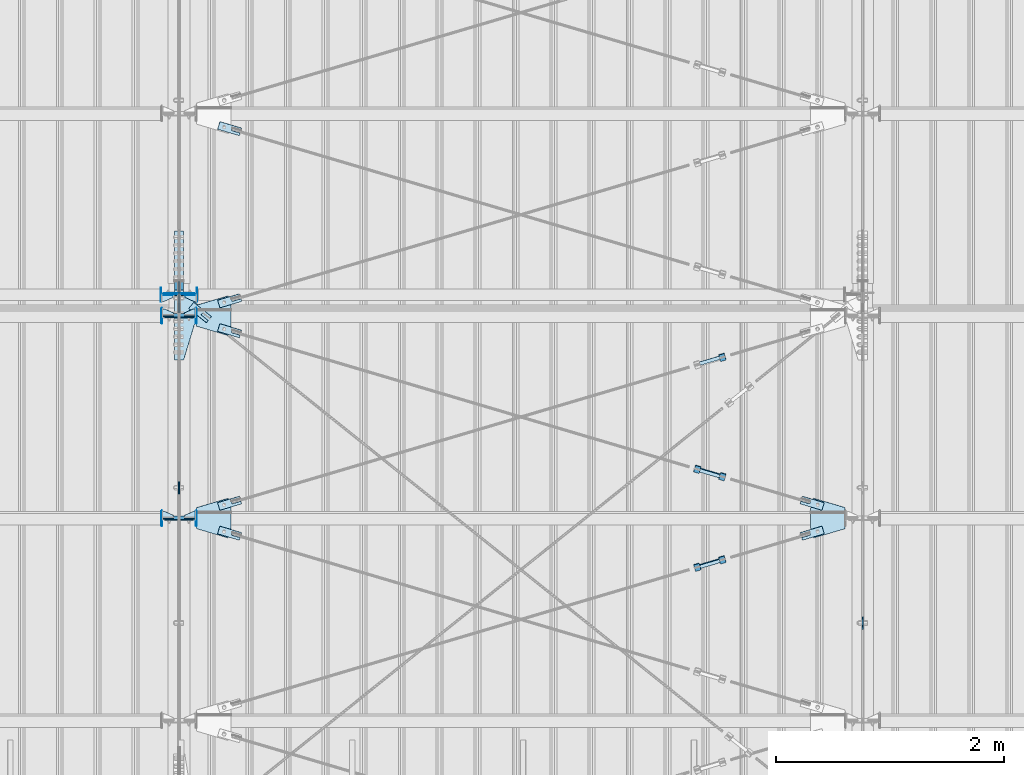
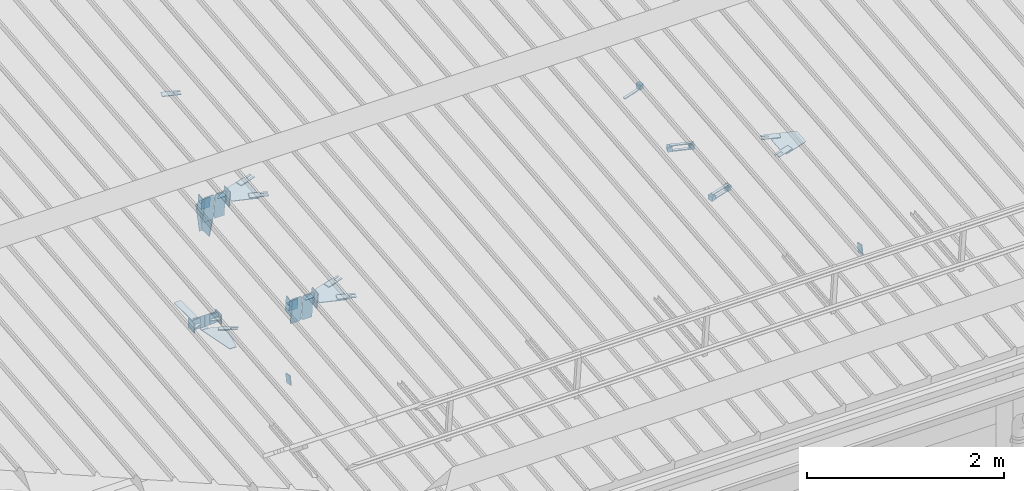
# One storey, part 148 of 709: 51 plates, 7 openings, 21 elements without a shape of their own.
"""IFC4 building model written with IfcOpenShell, lengths in millimetres."""

from ifc_helpers import new_model, si_unit, direction, frame, origin_with_axes, place, context, subcontext, project, spatial, line, indexed_curve, outline, extrude, material, element, aggregate, save


model = new_model("IFC4")

# Units and contexts
model_context = context("Model", 3, precision=0.2, world=origin_with_axes(), true_north=direction((0.0, 1.0)))
body_context = subcontext(model_context, "Body", "Model", "MODEL_VIEW")
ifc_project = project(units=[si_unit("LENGTHUNIT", "METRE", prefix="MILLI"), si_unit("AREAUNIT", "SQUARE_METRE"), si_unit("VOLUMEUNIT", "CUBIC_METRE"), si_unit("MASSUNIT", "GRAM", prefix="KILO"), si_unit("TIMEUNIT", "SECOND"), si_unit("PLANEANGLEUNIT", "RADIAN"), si_unit("SOLIDANGLEUNIT", "STERADIAN"), si_unit("THERMODYNAMICTEMPERATUREUNIT", "DEGREE_CELSIUS"), si_unit("LUMINOUSINTENSITYUNIT", "LUMEN")], contexts=[model_context])

# Site, building, storey
site_placement = place(None, origin_with_axes())
site = spatial("IfcSite", under=ifc_project, at=site_placement, CompositionType="ELEMENT")
building_placement = place(site_placement, origin_with_axes())
building = spatial("IfcBuilding", under=site, at=building_placement, Name="Undefined", CompositionType="ELEMENT")
storey_placement = place(building_placement, origin_with_axes())
storey = spatial("IfcBuildingStorey", under=building, at=storey_placement, Name="Undefined", CompositionType="ELEMENT", Elevation=0.0)

# Assembly, plates
assembly_1_placement = place(storey_placement, frame((40000.0, 346.0, 7089.70002), z_axis=(1.0, 0.0, 0.0), x_axis=(0.0, 0.9950371902, 0.099503719)))
assembly_1 = element("IfcElementAssembly", 1, at=assembly_1_placement, inside=storey)
ifc_material_1 = material(Name="C355-6", Category="STEEL")
plate_1_placement = place(assembly_1_placement, frame((5169.0059, 163.0, 127.0), z_axis=(-1.0, 0.0, 0.0), x_axis=(0.0, 0.0, -1.0)))
plate_1 = element("IfcPlate", 2, at=plate_1_placement, material=ifc_material_1, ObjectType="585", context=body_context, shape_type="SolidModel", body=[
    extrude(outline(indexed_curve([(0.0, 0.0), (108.0, 0.0), (123.0, 15.0), (123.0, 311.0), (108.0, 326.0), (0.0, 326.0)], segments=[line(1, 2, 3, 4, 5, 6, 1)])), frame((0.0, 0.0, 4.0), z_axis=(0.0, 0.0, 1.0), x_axis=(1.0, 0.0, 0.0)), (0.0, 0.0, -1.0), 8.0),
])
plate_2_placement = place(assembly_1_placement, frame((5169.0059, 163.0, -127.0), z_axis=(1.0, 0.0, 0.0), x_axis=(0.0, 0.0, 1.0)))
plate_2 = element("IfcPlate", 3, at=plate_2_placement, material=ifc_material_1, ObjectType="585", context=body_context, shape_type="SolidModel", body=[
    extrude(outline(indexed_curve([(0.0, 0.0), (108.0, 0.0), (123.0, 15.0), (123.0, 311.0), (108.0, 326.0), (0.0, 326.0)], segments=[line(1, 2, 3, 4, 5, 6, 1)])), frame((0.0, 0.0, 4.0), z_axis=(0.0, 0.0, 1.0), x_axis=(1.0, 0.0, 0.0)), (0.0, 0.0, -1.0), 8.0),
])
plate_3_placement = place(assembly_1_placement, frame((3383.44474, 163.0, 127.0), z_axis=(-1.0, 0.0, 0.0), x_axis=(0.0, 0.0, -1.0)))
plate_3 = element("IfcPlate", 4, at=plate_3_placement, material=ifc_material_1, ObjectType="585", context=body_context, shape_type="SolidModel", body=[
    extrude(outline(indexed_curve([(0.0, 0.0), (108.0, 0.0), (123.0, 15.0), (123.0, 311.0), (108.0, 326.0), (0.0, 326.0)], segments=[line(1, 2, 3, 4, 5, 6, 1)])), frame((0.0, 0.0, 4.0), z_axis=(0.0, 0.0, 1.0), x_axis=(1.0, 0.0, 0.0)), (0.0, 0.0, -1.0), 8.0),
])
plate_4_placement = place(assembly_1_placement, frame((3383.44474, 163.0, -127.0), z_axis=(1.0, 0.0, 0.0), x_axis=(0.0, 0.0, 1.0)))
plate_4 = element("IfcPlate", 5, at=plate_4_placement, material=ifc_material_1, ObjectType="585", context=body_context, shape_type="SolidModel", body=[
    extrude(outline(indexed_curve([(0.0, 0.0), (108.0, 0.0), (123.0, 15.0), (123.0, 311.0), (108.0, 326.0), (0.0, 326.0)], segments=[line(1, 2, 3, 4, 5, 6, 1)])), frame((0.0, 0.0, 4.0), z_axis=(0.0, 0.0, 1.0), x_axis=(1.0, 0.0, 0.0)), (0.0, 0.0, -1.0), 8.0),
])
plate_5_placement = place(assembly_1_placement, frame((5220.02987, -437.93487, 0.0), z_axis=(0.0, 0.0, -1.0), x_axis=(-0.1614213634, 0.9868855777, 0.0)))
plate_5 = element("IfcPlate", 6, at=plate_5_placement, material=ifc_material_1, ObjectType="442", context=body_context, shape_type="SolidModel", body=[
    extrude(outline(indexed_curve([(0.0, 0.0), (270.19115, 0.0), (225.20717, 275.01958), (-33.64648, 125.57036)], segments=[line(1, 2, 3, 4, 1)])), frame((0.0, 0.0, 6.0), z_axis=(0.0, 0.0, 1.0), x_axis=(1.0, 0.0, 0.0)), (0.0, 0.0, -1.0), 12.0),
])
plate_6_placement = place(assembly_1_placement, frame((5458.83099, -172.70172, -40.0), z_axis=(-0.9353786626, 0.3536477874, 0.0), x_axis=(-0.3536477874, -0.9353786626, 0.0)))
plate_6 = element("IfcPlate", 7, at=plate_6_placement, material=ifc_material_1, ObjectType="443", context=body_context, shape_type="SolidModel", body=[
    extrude(outline(indexed_curve([(0.0, 0.0), (298.89845, 0.0), (298.89845, 80.0), (0.0, 80.0)], segments=[line(1, 2, 3, 4, 1)])), frame((0.0, 0.0, 4.0), z_axis=(0.0, 0.0, 1.0), x_axis=(1.0, 0.0, 0.0)), (0.0, 0.0, -1.0), 8.0),
])
aggregate(assembly_1, [plate_1, plate_2, plate_3, plate_4, plate_5, plate_6])

# Assembly, plate
assembly_2_placement = place(storey_placement, frame((40000.0, 5665.09652, 5984.78262), z_axis=(-0.625451877, -0.7802627439, 1e-10), x_axis=(0.7742288439, -0.6206151549, 0.124123031)))
assembly_2 = element("IfcElementAssembly", 8, at=assembly_2_placement, inside=storey)
plate_7_placement = place(assembly_2_placement, frame((338.57474, -5.35577, -34.5878), z_axis=(1e-10, 0.9882227648, -0.1530221135), x_axis=(-1.0, 0.0, 0.0)))
plate_7 = element("IfcPlate", 9, at=plate_7_placement, material=ifc_material_1, ObjectType="488", context=body_context, shape_type="SolidModel", body=[
    extrude(outline(indexed_curve([(0.0, 0.0), (200.0, 0.0), (200.0, 70.0), (0.0, 70.0), (0.0, 46.0), (80.0, 46.0), (80.0, 24.0), (0.0, 24.0)], segments=[line(1, 2, 3, 4, 5, 6, 7, 8, 1)])), frame((0.0, 0.0, 4.0), z_axis=(0.0, 0.0, 1.0), x_axis=(1.0, 0.0, 0.0)), (0.0, 0.0, -1.0), 8.0),
])
aggregate(assembly_2, [plate_7])

# Assembly, plates
assembly_3_placement = place(storey_placement, frame((40000.0, 5668.61344, 5980.00002), z_axis=(1.0, 0.0, 0.0), x_axis=(0.0, 1.0, 0.0)))
assembly_3 = element("IfcElementAssembly", 10, at=assembly_3_placement, inside=storey)
plate_8_placement = place(assembly_3_placement, frame((12.38656, 164.3, 134.0), z_axis=(-1.0, 0.0, 0.0), x_axis=(0.0, 0.0, -1.0)))
plate_8 = element("IfcPlate", 11, at=plate_8_placement, material=ifc_material_1, ObjectType="558", context=body_context, shape_type="SolidModel", body=[
    extrude(outline(indexed_curve([(0.0, 0.0), (130.0, 0.0), (130.0, 140.0), (0.0, 140.0)], segments=[line(1, 2, 3, 4, 1)])), frame((0.0, 0.0, 4.0), z_axis=(0.0, 0.0, 1.0), x_axis=(1.0, 0.0, 0.0)), (0.0, 0.0, -1.0), 8.0),
])
plate_9_placement = place(assembly_3_placement, frame((12.38656, 164.3, -134.0), z_axis=(1.0, 0.0, 0.0), x_axis=(0.0, 0.0, 1.0)))
plate_9 = element("IfcPlate", 12, at=plate_9_placement, material=ifc_material_1, ObjectType="558", context=body_context, shape_type="SolidModel", body=[
    extrude(outline(indexed_curve([(0.0, 0.0), (130.0, 0.0), (130.0, 140.0), (0.0, 140.0)], segments=[line(1, 2, 3, 4, 1)])), frame((0.0, 0.0, 4.0), z_axis=(0.0, 0.0, 1.0), x_axis=(1.0, 0.0, 0.0)), (0.0, 0.0, -1.0), 8.0),
])
plate_10_placement = place(assembly_3_placement, frame((-0.78446, -3.92232, 40.0), z_axis=(0.1961161349, 0.9805806757, 0.0), x_axis=(0.0, 0.0, -1.0)))
plate_10 = element("IfcPlate", 13, at=plate_10_placement, material=ifc_material_1, ObjectType="487", context=body_context, shape_type="SolidModel", body=[
    extrude(outline(indexed_curve([(0.0, 0.0), (80.0, 0.0), (80.0, 579.50696), (0.0, 579.50696), (-116.23068, 190.22219), (-173.1922, 120.5416), (-95.76932, 57.25102)], segments=[line(1, 2, 3, 4, 5, 6, 7, 1)])), frame((0.0, 0.0, 4.0), z_axis=(0.0, 0.0, 1.0), x_axis=(1.0, 0.0, 0.0)), (0.0, 0.0, -1.0), 8.0),
])
plate_11_placement = place(assembly_3_placement, frame((564.38656, -4.0, -40.0), z_axis=(0.0, 1.0, 0.0), x_axis=(-1.0, 0.0, 0.0)))
plate_11 = element("IfcPlate", 14, at=plate_11_placement, material=ifc_material_1, ObjectType="446", context=body_context, shape_type="SolidModel", body=[
    extrude(outline(indexed_curve([(0.0, 0.0), (564.38656, 0.0), (564.38656, 80.0), (0.0, 80.0)], segments=[line(1, 2, 3, 4, 1)])), frame((0.0, 0.0, 4.0), z_axis=(0.0, 0.0, 1.0), x_axis=(1.0, 0.0, 0.0)), (0.0, 0.0, -1.0), 8.0),
])
aggregate(assembly_3, [plate_8, plate_9, plate_10, plate_11])

# Assembly, plate
assembly_4_placement = place(storey_placement, frame((40000.0, 3946.08299, 6446.88258), z_axis=(-1.0, 0.0, 0.0), x_axis=(0.0, 0.9805806757, -0.1961161349)))
assembly_4 = element("IfcElementAssembly", 15, at=assembly_4_placement, inside=storey)
plate_12_placement = place(assembly_4_placement, origin_with_axes())
plate_12 = element("IfcPlate", 16, at=plate_12_placement, material=ifc_material_1, ObjectType="491", context=body_context, shape_type="SolidModel", body=[
    extrude(outline(indexed_curve([(0.0, 0.0), (90.0, 0.0), (90.0, 110.0), (0.0, 110.0)], segments=[line(1, 2, 3, 4, 1)])), frame((0.0, 0.0, 6.0), z_axis=(0.0, 0.0, 1.0), x_axis=(1.0, 0.0, 0.0)), (0.0, 0.0, -1.0), 12.0),
])
aggregate(assembly_4, [plate_12])

assembly_5_placement = place(storey_placement, frame((46000.0, 2758.46612, 6684.40595), z_axis=(-1.0, 0.0, 0.0), x_axis=(0.0, 0.9805806757, -0.1961161349)))
assembly_5 = element("IfcElementAssembly", 17, at=assembly_5_placement, inside=storey)
plate_13_placement = place(assembly_5_placement, origin_with_axes())
plate_13 = element("IfcPlate", 18, at=plate_13_placement, material=ifc_material_1, ObjectType="491", context=body_context, shape_type="SolidModel", body=[
    extrude(outline(indexed_curve([(0.0, 0.0), (90.0, 0.0), (90.0, 110.0), (0.0, 110.0)], segments=[line(1, 2, 3, 4, 1)])), frame((0.0, 0.0, 6.0), z_axis=(0.0, 0.0, 1.0), x_axis=(1.0, 0.0, 0.0)), (0.0, 0.0, -1.0), 12.0),
])
aggregate(assembly_5, [plate_13])

# Assembly, plates
assembly_6_placement = place(storey_placement, frame((34000.0, 5673.0, 6074.30002), z_axis=(0.0, -1.0, 0.0), x_axis=(1.0, 0.0, 0.0)))
assembly_6 = element("IfcElementAssembly", 19, at=assembly_6_placement, inside=storey)
plate_14_placement = place(assembly_6_placement, frame((5842.0, 60.0, -60.0), z_axis=(1.0, 0.0, 0.0), x_axis=(0.0, 0.0, 1.0)))
plate_14 = element("IfcPlate", 20, at=plate_14_placement, material=ifc_material_1, ObjectType="559", context=body_context, shape_type="SolidModel", body=[
    extrude(outline(indexed_curve([(0.0, 0.0), (120.0, 0.0), (120.0, 120.0), (0.0, 120.0)], segments=[line(1, 2, 3, 4, 1)])), frame((0.0, 0.0, 4.0), z_axis=(0.0, 0.0, 1.0), x_axis=(1.0, 0.0, 0.0)), (0.0, 0.0, -1.0), 8.0),
])
plate_15_placement = place(assembly_6_placement, frame((5946.0, 60.0, 0.0), z_axis=(0.0, 0.0, -1.0), x_axis=(0.0, -1.0, 0.0)))
plate_15 = element("IfcPlate", 21, at=plate_15_placement, material=ifc_material_1, ObjectType="560", context=body_context, shape_type="SolidModel", body=[
    extrude(outline(indexed_curve([(0.0, 0.0), (120.0, 0.0), (120.0, 100.0), (0.0, 100.0)], segments=[line(1, 2, 3, 4, 1)])), frame((0.0, 0.0, 4.0), z_axis=(0.0, 0.0, 1.0), x_axis=(1.0, 0.0, 0.0)), (0.0, 0.0, -1.0), 8.0),
])
plate_16_placement = place(assembly_6_placement, frame((5946.0, 0.0, 60.0), z_axis=(0.0, 1.0, 0.0), x_axis=(0.0, 0.0, -1.0)))
plate_16 = element("IfcPlate", 22, at=plate_16_placement, material=ifc_material_1, ObjectType="561", context=body_context, shape_type="SolidModel", body=[
    extrude(outline(indexed_curve([(0.0, 80.0), (36.0, 0.0), (56.0, 0.0), (56.0, 90.0), (46.0, 100.0), (0.0, 100.0)], segments=[line(1, 2, 3, 4, 5, 6, 1)])), frame((0.0, 0.0, 4.0), z_axis=(0.0, 0.0, 1.0), x_axis=(1.0, 0.0, 0.0)), (0.0, 0.0, -1.0), 8.0),
])
aggregate(assembly_6, [plate_14, plate_15, plate_16])

assembly_7_placement = place(storey_placement, frame((40000.0, 5673.0, 6074.30002), z_axis=(0.0, -1.0, 0.0), x_axis=(1.0, 0.0, 0.0)))
assembly_7 = element("IfcElementAssembly", 23, at=assembly_7_placement, inside=storey)
plate_17_placement = place(assembly_7_placement, frame((158.0, -60.0, -60.0), z_axis=(-1.0, 0.0, 0.0), x_axis=(0.0, 0.0, 1.0)))
plate_17 = element("IfcPlate", 24, at=plate_17_placement, material=ifc_material_1, ObjectType="559", context=body_context, shape_type="SolidModel", body=[
    extrude(outline(indexed_curve([(0.0, 0.0), (120.0, 0.0), (120.0, 120.0), (0.0, 120.0)], segments=[line(1, 2, 3, 4, 1)])), frame((0.0, 0.0, 4.0), z_axis=(0.0, 0.0, 1.0), x_axis=(1.0, 0.0, 0.0)), (0.0, 0.0, -1.0), 8.0),
])
plate_18_placement = place(assembly_7_placement, frame((54.0, -60.0, 0.0), z_axis=(0.0, 0.0, -1.0), x_axis=(0.0, 1.0, 0.0)))
plate_18 = element("IfcPlate", 25, at=plate_18_placement, material=ifc_material_1, ObjectType="560", context=body_context, shape_type="SolidModel", body=[
    extrude(outline(indexed_curve([(0.0, 0.0), (120.0, 0.0), (120.0, 100.0), (0.0, 100.0)], segments=[line(1, 2, 3, 4, 1)])), frame((0.0, 0.0, 4.0), z_axis=(0.0, 0.0, 1.0), x_axis=(1.0, 0.0, 0.0)), (0.0, 0.0, -1.0), 8.0),
])
plate_19_placement = place(assembly_7_placement, frame((54.0, 0.0, 60.0), z_axis=(0.0, -1.0, 0.0), x_axis=(0.0, 0.0, -1.0)))
plate_19 = element("IfcPlate", 26, at=plate_19_placement, material=ifc_material_1, ObjectType="561", context=body_context, shape_type="SolidModel", body=[
    extrude(outline(indexed_curve([(0.0, 80.0), (36.0, 0.0), (56.0, 0.0), (56.0, 90.0), (46.0, 100.0), (0.0, 100.0)], segments=[line(1, 2, 3, 4, 5, 6, 1)])), frame((0.0, 0.0, 4.0), z_axis=(0.0, 0.0, 1.0), x_axis=(1.0, 0.0, 0.0)), (0.0, 0.0, -1.0), 8.0),
])
aggregate(assembly_7, [plate_17, plate_18, plate_19])

# Assembly, plate, voiding feature
assembly_8_placement = place(storey_placement, frame((44658.15773, 3315.21204, 7468.02522), z_axis=(0.2852311229, -0.9537021177, -0.0953702118), x_axis=(0.9584587662, 0.2838155751, 0.028381558)))
assembly_8 = element("IfcElementAssembly", 27, at=assembly_8_placement, inside=storey)
plate_20_placement = place(assembly_8_placement, frame((1036.9749, 0.0, 35.0), z_axis=(0.0, 1.0, 0.0), x_axis=(0.0, 0.0, -1.0)))
plate_20 = element("IfcPlate", 28, at=plate_20_placement, material=ifc_material_1, ObjectType="574", context=body_context, shape_type="SolidModel", body=[
    extrude(outline(indexed_curve([(0.0, 0.0), (70.0, 0.0), (70.0, 200.0), (0.0, 200.0)], segments=[line(1, 2, 3, 4, 1)])), frame((0.0, 0.0, 4.0), z_axis=(0.0, 0.0, 1.0), x_axis=(1.0, 0.0, 0.0)), (0.0, 0.0, -1.0), 8.0),
])
voiding_feature_1_placement = place(plate_20_placement, frame((24.0, 120.0, 0.0), z_axis=(0.0, 0.0, 1.0), x_axis=(1.0, 0.0, 0.0)))
element("IfcVoidingFeature", 29, at=voiding_feature_1_placement, cuts=plate_20, Name="PLATE", PredefinedType="HOLE", context=body_context, shape_type="SolidModel", body=[
    extrude(outline(indexed_curve([(0.0, 0.0), (22.0, 0.0), (22.0, 85.0), (0.0, 85.0)], segments=[line(1, 2, 3, 4, 1)])), frame((0.0, 0.0, 6.5), z_axis=(0.0, 0.0, 1.0), x_axis=(1.0, 0.0, 0.0)), (0.0, 0.0, -1.0), 13.0),
])
aggregate(assembly_8, [plate_20])

# Assembly, plates
assembly_9_placement = place(storey_placement, frame((44776.93742, 3316.25466, 7498.27911), z_axis=(-0.9584587662, -0.2838155751, -0.0283815575), x_axis=(-0.2852311229, 0.9537021176, 0.095370212)))
assembly_9 = element("IfcElementAssembly", 30, at=assembly_9_placement, inside=storey)
ifc_material_2 = material(Name="Steel_Undefined", Category="STEEL")
plate_21_placement = place(assembly_9_placement, frame((15.0, 66.0, 230.0), z_axis=(0.0, 1.0, 0.0), x_axis=(1.0, 0.0, 0.0)))
plate_21 = element("IfcPlate", 31, at=plate_21_placement, material=ifc_material_2, ObjectType="484", context=body_context, shape_type="SolidModel", body=[
    extrude(outline(indexed_curve([(0.0, 0.0), (30.0, 0.0), (30.0, 230.0), (0.0, 230.0)], segments=[line(1, 2, 3, 4, 1)])), frame((0.0, 0.0, 6.0), z_axis=(0.0, 0.0, 1.0), x_axis=(1.0, 0.0, 0.0)), (0.0, 0.0, -1.0), 12.0),
])
plate_22_placement = place(assembly_9_placement, origin_with_axes())
plate_22 = element("IfcPlate", 32, at=plate_22_placement, material=ifc_material_2, ObjectType="482", context=body_context, shape_type="SolidModel", body=[
    extrude(outline(indexed_curve([(0.0, 0.0), (60.0, 0.0), (60.0, 60.0), (0.0, 60.0)], segments=[line(1, 2, 3, 4, 1)])), frame((0.0, 0.0, 25.0), z_axis=(0.0, 0.0, 1.0), x_axis=(1.0, 0.0, 0.0)), (0.0, 0.0, -1.0), 50.0),
])
plate_23_placement = place(assembly_9_placement, frame((15.0, -6.0, 230.0), z_axis=(0.0, 1.0, 0.0), x_axis=(1.0, 0.0, 0.0)))
plate_23 = element("IfcPlate", 33, at=plate_23_placement, material=ifc_material_2, ObjectType="484", context=body_context, shape_type="SolidModel", body=[
    extrude(outline(indexed_curve([(0.0, 0.0), (30.0, 0.0), (30.0, 230.0), (0.0, 230.0)], segments=[line(1, 2, 3, 4, 1)])), frame((0.0, 0.0, 6.0), z_axis=(0.0, 0.0, 1.0), x_axis=(1.0, 0.0, 0.0)), (0.0, 0.0, -1.0), 12.0),
])
plate_24_placement = place(assembly_9_placement, frame((0.0, 0.0, 230.0), z_axis=(0.0, 0.0, 1.0), x_axis=(1.0, 0.0, 0.0)))
plate_24 = element("IfcPlate", 34, at=plate_24_placement, material=ifc_material_2, ObjectType="483", context=body_context, shape_type="SolidModel", body=[
    extrude(outline(indexed_curve([(0.0, 0.0), (60.0, 0.0), (60.0, 60.0), (0.0, 60.0)], segments=[line(1, 2, 3, 4, 1)])), frame((0.0, 0.0, 25.0), z_axis=(0.0, 0.0, 1.0), x_axis=(1.0, 0.0, 0.0)), (0.0, 0.0, -1.0), 50.0),
])
aggregate(assembly_9, [plate_21, plate_22, plate_23, plate_24])

# Assembly, plate, voiding feature
assembly_10_placement = place(storey_placement, frame((40000.0, 3712.55385, 7507.7594), z_axis=(-0.2852311229, -0.9537021177, -0.0953702118), x_axis=(0.9584587662, -0.2838155751, -0.028381558)))
assembly_10 = element("IfcElementAssembly", 35, at=assembly_10_placement, inside=storey)
plate_25_placement = place(assembly_10_placement, frame((363.0251, 0.0, -35.0), z_axis=(0.0, 1.0, 0.0), x_axis=(0.0, 0.0, 1.0)))
plate_25 = element("IfcPlate", 36, at=plate_25_placement, material=ifc_material_1, ObjectType="574", context=body_context, shape_type="SolidModel", body=[
    extrude(outline(indexed_curve([(0.0, 0.0), (70.0, 0.0), (70.0, 200.0), (0.0, 200.0)], segments=[line(1, 2, 3, 4, 1)])), frame((0.0, 0.0, 4.0), z_axis=(0.0, 0.0, 1.0), x_axis=(1.0, 0.0, 0.0)), (0.0, 0.0, -1.0), 8.0),
])
voiding_feature_2_placement = place(plate_25_placement, frame((24.0, 120.0, 0.0), z_axis=(0.0, 0.0, 1.0), x_axis=(1.0, 0.0, 0.0)))
element("IfcVoidingFeature", 37, at=voiding_feature_2_placement, cuts=plate_25, Name="PLATE", PredefinedType="HOLE", context=body_context, shape_type="SolidModel", body=[
    extrude(outline(indexed_curve([(0.0, 0.0), (22.0, 0.0), (22.0, 85.0), (0.0, 85.0)], segments=[line(1, 2, 3, 4, 1)])), frame((0.0, 0.0, 6.5), z_axis=(0.0, 0.0, 1.0), x_axis=(1.0, 0.0, 0.0)), (0.0, 0.0, -1.0), 13.0),
])
aggregate(assembly_10, [plate_25])

assembly_11_placement = place(storey_placement, frame((40000.0, 3712.55385, 7507.7594), z_axis=(0.2852311229, -0.9537021177, -0.0953702118), x_axis=(0.9584587662, 0.2838155751, 0.028381558)))
assembly_11 = element("IfcElementAssembly", 38, at=assembly_11_placement, inside=storey)
plate_26_placement = place(assembly_11_placement, frame((363.0251, 0.0, -35.0), z_axis=(0.0, 1.0, 0.0), x_axis=(0.0, 0.0, 1.0)))
plate_26 = element("IfcPlate", 39, at=plate_26_placement, material=ifc_material_1, ObjectType="574", context=body_context, shape_type="SolidModel", body=[
    extrude(outline(indexed_curve([(0.0, 0.0), (70.0, 0.0), (70.0, 200.0), (0.0, 200.0)], segments=[line(1, 2, 3, 4, 1)])), frame((0.0, 0.0, 4.0), z_axis=(0.0, 0.0, 1.0), x_axis=(1.0, 0.0, 0.0)), (0.0, 0.0, -1.0), 8.0),
])
voiding_feature_3_placement = place(plate_26_placement, frame((24.0, 120.0, 0.0), z_axis=(0.0, 0.0, 1.0), x_axis=(1.0, 0.0, 0.0)))
element("IfcVoidingFeature", 40, at=voiding_feature_3_placement, cuts=plate_26, Name="PLATE", PredefinedType="HOLE", context=body_context, shape_type="SolidModel", body=[
    extrude(outline(indexed_curve([(0.0, 0.0), (22.0, 0.0), (22.0, 85.0), (0.0, 85.0)], segments=[line(1, 2, 3, 4, 1)])), frame((0.0, 0.0, 6.5), z_axis=(0.0, 0.0, 1.0), x_axis=(1.0, 0.0, 0.0)), (0.0, 0.0, -1.0), 13.0),
])
aggregate(assembly_11, [plate_26])

# Assembly, plates
assembly_12_placement = place(storey_placement, frame((44776.93742, 5092.95441, 7675.94908), z_axis=(-0.9584587662, -0.2838155751, -0.0283815575), x_axis=(-0.2852311229, 0.9537021176, 0.095370212)))
assembly_12 = element("IfcElementAssembly", 41, at=assembly_12_placement, inside=storey)
plate_27_placement = place(assembly_12_placement, frame((15.0, 66.0, 230.0), z_axis=(0.0, 1.0, 0.0), x_axis=(1.0, 0.0, 0.0)))
plate_27 = element("IfcPlate", 42, at=plate_27_placement, material=ifc_material_2, ObjectType="484", context=body_context, shape_type="SolidModel", body=[
    extrude(outline(indexed_curve([(0.0, 0.0), (30.0, 0.0), (30.0, 230.0), (0.0, 230.0)], segments=[line(1, 2, 3, 4, 1)])), frame((0.0, 0.0, 6.0), z_axis=(0.0, 0.0, 1.0), x_axis=(1.0, 0.0, 0.0)), (0.0, 0.0, -1.0), 12.0),
])
plate_28_placement = place(assembly_12_placement, origin_with_axes())
plate_28 = element("IfcPlate", 43, at=plate_28_placement, material=ifc_material_2, ObjectType="482", context=body_context, shape_type="SolidModel", body=[
    extrude(outline(indexed_curve([(0.0, 0.0), (60.0, 0.0), (60.0, 60.0), (0.0, 60.0)], segments=[line(1, 2, 3, 4, 1)])), frame((0.0, 0.0, 25.0), z_axis=(0.0, 0.0, 1.0), x_axis=(1.0, 0.0, 0.0)), (0.0, 0.0, -1.0), 50.0),
])
aggregate(assembly_12, [plate_27, plate_28])

# Assembly, plate, voiding feature
assembly_13_placement = place(storey_placement, frame((40000.0, 5489.2536, 7685.42938), z_axis=(-0.2852311229, -0.9537021177, -0.0953702118), x_axis=(0.9584587662, -0.2838155751, -0.028381558)))
assembly_13 = element("IfcElementAssembly", 44, at=assembly_13_placement, inside=storey)
plate_29_placement = place(assembly_13_placement, frame((363.0251, 0.0, -35.0), z_axis=(0.0, 1.0, 0.0), x_axis=(0.0, 0.0, 1.0)))
plate_29 = element("IfcPlate", 45, at=plate_29_placement, material=ifc_material_1, ObjectType="574", context=body_context, shape_type="SolidModel", body=[
    extrude(outline(indexed_curve([(0.0, 0.0), (70.0, 0.0), (70.0, 200.0), (0.0, 200.0)], segments=[line(1, 2, 3, 4, 1)])), frame((0.0, 0.0, 4.0), z_axis=(0.0, 0.0, 1.0), x_axis=(1.0, 0.0, 0.0)), (0.0, 0.0, -1.0), 8.0),
])
voiding_feature_4_placement = place(plate_29_placement, frame((24.0, 120.0, 0.0), z_axis=(0.0, 0.0, 1.0), x_axis=(1.0, 0.0, 0.0)))
element("IfcVoidingFeature", 46, at=voiding_feature_4_placement, cuts=plate_29, Name="PLATE", PredefinedType="HOLE", context=body_context, shape_type="SolidModel", body=[
    extrude(outline(indexed_curve([(0.0, 0.0), (22.0, 0.0), (22.0, 85.0), (0.0, 85.0)], segments=[line(1, 2, 3, 4, 1)])), frame((0.0, 0.0, 6.5), z_axis=(0.0, 0.0, 1.0), x_axis=(1.0, 0.0, 0.0)), (0.0, 0.0, -1.0), 13.0),
])
aggregate(assembly_13, [plate_29])

assembly_14_placement = place(storey_placement, frame((44658.15773, 4109.89565, 7547.49358), z_axis=(-0.2852311229, -0.9537021177, -0.0953702118), x_axis=(0.9584587662, -0.2838155751, -0.028381558)))
assembly_14 = element("IfcElementAssembly", 47, at=assembly_14_placement, inside=storey)
plate_30_placement = place(assembly_14_placement, frame((1036.9749, 0.0, 35.0), z_axis=(0.0, 1.0, 0.0), x_axis=(0.0, 0.0, -1.0)))
plate_30 = element("IfcPlate", 48, at=plate_30_placement, material=ifc_material_1, ObjectType="574", context=body_context, shape_type="SolidModel", body=[
    extrude(outline(indexed_curve([(0.0, 0.0), (70.0, 0.0), (70.0, 200.0), (0.0, 200.0)], segments=[line(1, 2, 3, 4, 1)])), frame((0.0, 0.0, 4.0), z_axis=(0.0, 0.0, 1.0), x_axis=(1.0, 0.0, 0.0)), (0.0, 0.0, -1.0), 8.0),
])
voiding_feature_5_placement = place(plate_30_placement, frame((24.0, 120.0, 0.0), z_axis=(0.0, 0.0, 1.0), x_axis=(1.0, 0.0, 0.0)))
element("IfcVoidingFeature", 49, at=voiding_feature_5_placement, cuts=plate_30, Name="PLATE", PredefinedType="HOLE", context=body_context, shape_type="SolidModel", body=[
    extrude(outline(indexed_curve([(0.0, 0.0), (22.0, 0.0), (22.0, 85.0), (0.0, 85.0)], segments=[line(1, 2, 3, 4, 1)])), frame((0.0, 0.0, 6.5), z_axis=(0.0, 0.0, 1.0), x_axis=(1.0, 0.0, 0.0)), (0.0, 0.0, -1.0), 13.0),
])
aggregate(assembly_14, [plate_30])

# Assembly, plates
assembly_15_placement = place(storey_placement, frame((44759.82355, 4045.66069, 7571.21971), z_axis=(-0.9584587662, 0.2838155751, 0.0283815575), x_axis=(0.2852311229, 0.9537021176, 0.095370212)))
assembly_15 = element("IfcElementAssembly", 50, at=assembly_15_placement, inside=storey)
plate_31_placement = place(assembly_15_placement, frame((15.0, 66.0, 230.0), z_axis=(0.0, 1.0, 0.0), x_axis=(1.0, 0.0, 0.0)))
plate_31 = element("IfcPlate", 51, at=plate_31_placement, material=ifc_material_2, ObjectType="484", context=body_context, shape_type="SolidModel", body=[
    extrude(outline(indexed_curve([(0.0, 0.0), (30.0, 0.0), (30.0, 230.0), (0.0, 230.0)], segments=[line(1, 2, 3, 4, 1)])), frame((0.0, 0.0, 6.0), z_axis=(0.0, 0.0, 1.0), x_axis=(1.0, 0.0, 0.0)), (0.0, 0.0, -1.0), 12.0),
])
plate_32_placement = place(assembly_15_placement, origin_with_axes())
plate_32 = element("IfcPlate", 52, at=plate_32_placement, material=ifc_material_2, ObjectType="482", context=body_context, shape_type="SolidModel", body=[
    extrude(outline(indexed_curve([(0.0, 0.0), (60.0, 0.0), (60.0, 60.0), (0.0, 60.0)], segments=[line(1, 2, 3, 4, 1)])), frame((0.0, 0.0, 25.0), z_axis=(0.0, 0.0, 1.0), x_axis=(1.0, 0.0, 0.0)), (0.0, 0.0, -1.0), 50.0),
])
plate_33_placement = place(assembly_15_placement, frame((0.0, 0.0, 230.0), z_axis=(0.0, 0.0, 1.0), x_axis=(1.0, 0.0, 0.0)))
plate_33 = element("IfcPlate", 53, at=plate_33_placement, material=ifc_material_2, ObjectType="483", context=body_context, shape_type="SolidModel", body=[
    extrude(outline(indexed_curve([(0.0, 0.0), (60.0, 0.0), (60.0, 60.0), (0.0, 60.0)], segments=[line(1, 2, 3, 4, 1)])), frame((0.0, 0.0, 25.0), z_axis=(0.0, 0.0, 1.0), x_axis=(1.0, 0.0, 0.0)), (0.0, 0.0, -1.0), 50.0),
])
plate_34_placement = place(assembly_15_placement, frame((15.0, -6.0, 230.0), z_axis=(0.0, 1.0, 0.0), x_axis=(1.0, 0.0, 0.0)))
plate_34 = element("IfcPlate", 54, at=plate_34_placement, material=ifc_material_2, ObjectType="484", context=body_context, shape_type="SolidModel", body=[
    extrude(outline(indexed_curve([(0.0, 0.0), (30.0, 0.0), (30.0, 230.0), (0.0, 230.0)], segments=[line(1, 2, 3, 4, 1)])), frame((0.0, 0.0, 6.0), z_axis=(0.0, 0.0, 1.0), x_axis=(1.0, 0.0, 0.0)), (0.0, 0.0, -1.0), 12.0),
])
aggregate(assembly_15, [plate_31, plate_32, plate_33, plate_34])

# Assembly, plate, voiding feature
assembly_16_placement = place(storey_placement, frame((40000.0, 5489.2536, 7685.42938), z_axis=(0.2847296511, -0.9538504697, -0.095385047), x_axis=(0.9586078582, 0.2833165921, 0.028331659)))
assembly_16 = element("IfcElementAssembly", 55, at=assembly_16_placement, inside=storey)
plate_35_placement = place(assembly_16_placement, frame((363.68279, 0.0, -35.0), z_axis=(0.0, 1.0, 0.0), x_axis=(0.0, 0.0, 1.0)))
plate_35 = element("IfcPlate", 56, at=plate_35_placement, material=ifc_material_1, ObjectType="574", context=body_context, shape_type="SolidModel", body=[
    extrude(outline(indexed_curve([(0.0, 0.0), (70.0, 0.0), (70.0, 200.0), (0.0, 200.0)], segments=[line(1, 2, 3, 4, 1)])), frame((0.0, 0.0, 4.0), z_axis=(0.0, 0.0, 1.0), x_axis=(1.0, 0.0, 0.0)), (0.0, 0.0, -1.0), 8.0),
])
voiding_feature_6_placement = place(plate_35_placement, frame((24.0, 120.0, 0.0), z_axis=(0.0, 0.0, 1.0), x_axis=(1.0, 0.0, 0.0)))
element("IfcVoidingFeature", 57, at=voiding_feature_6_placement, cuts=plate_35, Name="PLATE", PredefinedType="HOLE", context=body_context, shape_type="SolidModel", body=[
    extrude(outline(indexed_curve([(0.0, 0.0), (22.0, 0.0), (22.0, 85.0), (0.0, 85.0)], segments=[line(1, 2, 3, 4, 1)])), frame((0.0, 0.0, 6.5), z_axis=(0.0, 0.0, 1.0), x_axis=(1.0, 0.0, 0.0)), (0.0, 0.0, -1.0), 13.0),
])
aggregate(assembly_16, [plate_35])

assembly_17_placement = place(storey_placement, frame((40000.0, 7262.55385, 7862.7594), z_axis=(-0.2847296511, -0.9538504697, -0.095385047), x_axis=(0.9586078582, -0.2833165921, -0.028331659)))
assembly_17 = element("IfcElementAssembly", 58, at=assembly_17_placement, inside=storey)
plate_36_placement = place(assembly_17_placement, frame((363.68279, 0.0, -35.0), z_axis=(0.0, 1.0, 0.0), x_axis=(0.0, 0.0, 1.0)))
plate_36 = element("IfcPlate", 59, at=plate_36_placement, material=ifc_material_1, ObjectType="574", context=body_context, shape_type="SolidModel", body=[
    extrude(outline(indexed_curve([(0.0, 0.0), (70.0, 0.0), (70.0, 200.0), (0.0, 200.0)], segments=[line(1, 2, 3, 4, 1)])), frame((0.0, 0.0, 4.0), z_axis=(0.0, 0.0, 1.0), x_axis=(1.0, 0.0, 0.0)), (0.0, 0.0, -1.0), 8.0),
])
voiding_feature_7_placement = place(plate_36_placement, frame((24.0, 120.0, 0.0), z_axis=(0.0, 0.0, 1.0), x_axis=(1.0, 0.0, 0.0)))
element("IfcVoidingFeature", 60, at=voiding_feature_7_placement, cuts=plate_36, Name="PLATE", PredefinedType="HOLE", context=body_context, shape_type="SolidModel", body=[
    extrude(outline(indexed_curve([(0.0, 0.0), (22.0, 0.0), (22.0, 85.0), (0.0, 85.0)], segments=[line(1, 2, 3, 4, 1)])), frame((0.0, 0.0, 6.5), z_axis=(0.0, 0.0, 1.0), x_axis=(1.0, 0.0, 0.0)), (0.0, 0.0, -1.0), 13.0),
])
aggregate(assembly_17, [plate_36])

# Assembly, plates
assembly_18_placement = place(storey_placement, frame((34000.0, 3713.34988, 7499.7991), z_axis=(0.0, 0.9950371902, 0.099503719), x_axis=(1.0, 0.0, 0.0)))
assembly_18 = element("IfcElementAssembly", 61, at=assembly_18_placement, inside=storey)
plate_37_placement = place(assembly_18_placement, frame((5953.0, 0.0, 60.0), z_axis=(0.0, -1.0, 0.0), x_axis=(-1.0, 0.0, 0.0)))
plate_37 = element("IfcPlate", 62, at=plate_37_placement, material=ifc_material_1, ObjectType="588", context=body_context, shape_type="SolidModel", body=[
    extrude(outline(indexed_curve([(0.0, 36.0), (80.0, 0.0), (100.0, 0.0), (100.0, 56.0), (0.0, 56.0)], segments=[line(1, 2, 3, 4, 5, 1)])), frame((0.0, 0.0, 4.0), z_axis=(0.0, 0.0, 1.0), x_axis=(1.0, 0.0, 0.0)), (0.0, 0.0, -1.0), 8.0),
])
plate_38_placement = place(assembly_18_placement, frame((5953.0, 65.0, 0.0), z_axis=(0.0, 0.0, 1.0), x_axis=(-1.0, 0.0, 0.0)))
plate_38 = element("IfcPlate", 63, at=plate_38_placement, material=ifc_material_1, ObjectType="587", context=body_context, shape_type="SolidModel", body=[
    extrude(outline(indexed_curve([(0.0, 0.0), (100.0, 0.0), (100.0, 130.0), (0.0, 130.0)], segments=[line(1, 2, 3, 4, 1)])), frame((0.0, 0.0, 4.0), z_axis=(0.0, 0.0, 1.0), x_axis=(1.0, 0.0, 0.0)), (0.0, 0.0, -1.0), 8.0),
])
plate_39_placement = place(assembly_18_placement, frame((5849.0, -98.0, 60.0), z_axis=(1.0, 0.0, 0.0), x_axis=(0.0, 0.0, -1.0)))
plate_39 = element("IfcPlate", 64, at=plate_39_placement, material=ifc_material_1, ObjectType="586", context=body_context, shape_type="SolidModel", body=[
    extrude(outline(indexed_curve([(0.0, 0.0), (120.0, 0.0), (120.0, 196.0), (0.0, 196.0)], segments=[line(1, 2, 3, 4, 1)])), frame((0.0, 0.0, 4.0), z_axis=(0.0, 0.0, 1.0), x_axis=(1.0, 0.0, 0.0)), (0.0, 0.0, -1.0), 8.0),
])
aggregate(assembly_18, [plate_37, plate_38, plate_39])

assembly_19_placement = place(storey_placement, frame((34000.0, 5490.04963, 7677.46908), z_axis=(0.0, 0.9950371902, 0.099503719), x_axis=(1.0, 0.0, 0.0)))
assembly_19 = element("IfcElementAssembly", 65, at=assembly_19_placement, inside=storey)
plate_40_placement = place(assembly_19_placement, frame((5953.0, 65.0, 0.0), z_axis=(0.0, 0.0, 1.0), x_axis=(-1.0, 0.0, 0.0)))
plate_40 = element("IfcPlate", 66, at=plate_40_placement, material=ifc_material_1, ObjectType="587", context=body_context, shape_type="SolidModel", body=[
    extrude(outline(indexed_curve([(0.0, 0.0), (100.0, 0.0), (100.0, 130.0), (0.0, 130.0)], segments=[line(1, 2, 3, 4, 1)])), frame((0.0, 0.0, 4.0), z_axis=(0.0, 0.0, 1.0), x_axis=(1.0, 0.0, 0.0)), (0.0, 0.0, -1.0), 8.0),
])
plate_41_placement = place(assembly_19_placement, frame((5953.0, 0.0, 60.0), z_axis=(0.0, -1.0, 0.0), x_axis=(-1.0, 0.0, 0.0)))
plate_41 = element("IfcPlate", 67, at=plate_41_placement, material=ifc_material_1, ObjectType="588", context=body_context, shape_type="SolidModel", body=[
    extrude(outline(indexed_curve([(0.0, 36.0), (80.0, 0.0), (100.0, 0.0), (100.0, 56.0), (0.0, 56.0)], segments=[line(1, 2, 3, 4, 5, 1)])), frame((0.0, 0.0, 4.0), z_axis=(0.0, 0.0, 1.0), x_axis=(1.0, 0.0, 0.0)), (0.0, 0.0, -1.0), 8.0),
])
plate_42_placement = place(assembly_19_placement, frame((5849.0, -98.0, 60.0), z_axis=(1.0, 0.0, 0.0), x_axis=(0.0, 0.0, -1.0)))
plate_42 = element("IfcPlate", 68, at=plate_42_placement, material=ifc_material_1, ObjectType="586", context=body_context, shape_type="SolidModel", body=[
    extrude(outline(indexed_curve([(0.0, 0.0), (120.0, 0.0), (120.0, 196.0), (0.0, 196.0)], segments=[line(1, 2, 3, 4, 1)])), frame((0.0, 0.0, 4.0), z_axis=(0.0, 0.0, 1.0), x_axis=(1.0, 0.0, 0.0)), (0.0, 0.0, -1.0), 8.0),
])
aggregate(assembly_19, [plate_40, plate_41, plate_42])

assembly_20_placement = place(storey_placement, frame((40000.0, 3713.34988, 7499.7991), z_axis=(0.0, 0.9950371902, 0.099503719), x_axis=(1.0, 0.0, 0.0)))
assembly_20 = element("IfcElementAssembly", 69, at=assembly_20_placement, inside=storey)
plate_43_placement = place(assembly_20_placement, frame((47.0, 0.0, 60.0), z_axis=(0.0, 1.0, 0.0), x_axis=(1.0, 0.0, 0.0)))
plate_43 = element("IfcPlate", 70, at=plate_43_placement, material=ifc_material_1, ObjectType="588", context=body_context, shape_type="SolidModel", body=[
    extrude(outline(indexed_curve([(0.0, 36.0), (80.0, 0.0), (100.0, 0.0), (100.0, 56.0), (0.0, 56.0)], segments=[line(1, 2, 3, 4, 5, 1)])), frame((0.0, 0.0, 4.0), z_axis=(0.0, 0.0, 1.0), x_axis=(1.0, 0.0, 0.0)), (0.0, 0.0, -1.0), 8.0),
])
plate_44_placement = place(assembly_20_placement, frame((47.0, -65.0, 0.0), z_axis=(0.0, 0.0, 1.0), x_axis=(1.0, 0.0, 0.0)))
plate_44 = element("IfcPlate", 71, at=plate_44_placement, material=ifc_material_1, ObjectType="587", context=body_context, shape_type="SolidModel", body=[
    extrude(outline(indexed_curve([(0.0, 0.0), (100.0, 0.0), (100.0, 130.0), (0.0, 130.0)], segments=[line(1, 2, 3, 4, 1)])), frame((0.0, 0.0, 4.0), z_axis=(0.0, 0.0, 1.0), x_axis=(1.0, 0.0, 0.0)), (0.0, 0.0, -1.0), 8.0),
])
plate_45_placement = place(assembly_20_placement, frame((151.0, -98.0, -60.0), z_axis=(-1.0, 0.0, 0.0), x_axis=(0.0, 0.0, 1.0)))
plate_45 = element("IfcPlate", 72, at=plate_45_placement, material=ifc_material_1, ObjectType="586", context=body_context, shape_type="SolidModel", body=[
    extrude(outline(indexed_curve([(0.0, 0.0), (120.0, 0.0), (120.0, 196.0), (0.0, 196.0)], segments=[line(1, 2, 3, 4, 1)])), frame((0.0, 0.0, 4.0), z_axis=(0.0, 0.0, 1.0), x_axis=(1.0, 0.0, 0.0)), (0.0, 0.0, -1.0), 8.0),
])
plate_46_placement = place(assembly_20_placement, frame((154.99945, 0.0, 93.07721), z_axis=(0.0, -1.0, 0.0), x_axis=(0.0, 0.0, -1.0)))
plate_46 = element("IfcPlate", 73, at=plate_46_placement, material=ifc_material_1, ObjectType="576", context=body_context, shape_type="SolidModel", body=[
    extrude(outline(indexed_curve([(0.0, 0.0), (186.15442, 0.0), (268.27702, 275.95562), (182.01573, 301.62642), (4.13868, 301.62642), (-82.1226, 275.95562)], segments=[line(1, 2, 3, 4, 5, 6, 1)])), frame((0.0, 0.0, 4.0), z_axis=(0.0, 0.0, 1.0), x_axis=(1.0, 0.0, 0.0)), (0.0, 0.0, -1.0), 8.0),
])
plate_47_placement = place(assembly_20_placement, frame((5845.00055, 0.0, -93.07721), z_axis=(0.0, -1.0, 0.0), x_axis=(0.0, 0.0, 1.0)))
plate_47 = element("IfcPlate", 74, at=plate_47_placement, material=ifc_material_1, ObjectType="576", context=body_context, shape_type="SolidModel", body=[
    extrude(outline(indexed_curve([(0.0, 0.0), (186.15442, 0.0), (268.27702, 275.95562), (182.01573, 301.62642), (4.13868, 301.62642), (-82.1226, 275.95562)], segments=[line(1, 2, 3, 4, 5, 6, 1)])), frame((0.0, 0.0, 4.0), z_axis=(0.0, 0.0, 1.0), x_axis=(1.0, 0.0, 0.0)), (0.0, 0.0, -1.0), 8.0),
])
aggregate(assembly_20, [plate_43, plate_44, plate_45, plate_46, plate_47])

assembly_21_placement = place(storey_placement, frame((40000.0, 5490.04963, 7677.46908), z_axis=(0.0, 0.9950371902, 0.099503719), x_axis=(1.0, 0.0, 0.0)))
assembly_21 = element("IfcElementAssembly", 75, at=assembly_21_placement, inside=storey)
plate_48_placement = place(assembly_21_placement, frame((47.0, 0.0, 60.0), z_axis=(0.0, 1.0, 0.0), x_axis=(1.0, 0.0, 0.0)))
plate_48 = element("IfcPlate", 76, at=plate_48_placement, material=ifc_material_1, ObjectType="588", context=body_context, shape_type="SolidModel", body=[
    extrude(outline(indexed_curve([(0.0, 36.0), (80.0, 0.0), (100.0, 0.0), (100.0, 56.0), (0.0, 56.0)], segments=[line(1, 2, 3, 4, 5, 1)])), frame((0.0, 0.0, 4.0), z_axis=(0.0, 0.0, 1.0), x_axis=(1.0, 0.0, 0.0)), (0.0, 0.0, -1.0), 8.0),
])
plate_49_placement = place(assembly_21_placement, frame((151.0, -98.0, -60.0), z_axis=(-1.0, 0.0, 0.0), x_axis=(0.0, 0.0, 1.0)))
plate_49 = element("IfcPlate", 77, at=plate_49_placement, material=ifc_material_1, ObjectType="586", context=body_context, shape_type="SolidModel", body=[
    extrude(outline(indexed_curve([(0.0, 0.0), (120.0, 0.0), (120.0, 196.0), (0.0, 196.0)], segments=[line(1, 2, 3, 4, 1)])), frame((0.0, 0.0, 4.0), z_axis=(0.0, 0.0, 1.0), x_axis=(1.0, 0.0, 0.0)), (0.0, 0.0, -1.0), 8.0),
])
plate_50_placement = place(assembly_21_placement, frame((47.0, -65.0, 0.0), z_axis=(0.0, 0.0, 1.0), x_axis=(1.0, 0.0, 0.0)))
plate_50 = element("IfcPlate", 78, at=plate_50_placement, material=ifc_material_1, ObjectType="587", context=body_context, shape_type="SolidModel", body=[
    extrude(outline(indexed_curve([(0.0, 0.0), (100.0, 0.0), (100.0, 130.0), (0.0, 130.0)], segments=[line(1, 2, 3, 4, 1)])), frame((0.0, 0.0, 4.0), z_axis=(0.0, 0.0, 1.0), x_axis=(1.0, 0.0, 0.0)), (0.0, 0.0, -1.0), 8.0),
])
plate_51_placement = place(assembly_21_placement, frame((154.99945, 0.0, 92.98165), z_axis=(0.0, -1.0, 0.0), x_axis=(0.0, 0.0, -1.0)))
plate_51 = element("IfcPlate", 79, at=plate_51_placement, material=ifc_material_1, ObjectType="576", context=body_context, shape_type="SolidModel", body=[
    extrude(outline(indexed_curve([(0.0, 0.0), (186.05886, 0.0), (268.18146, 275.95562), (181.92017, 301.62642), (4.09476, 302.30336), (-82.17995, 276.67769)], segments=[line(1, 2, 3, 4, 5, 6, 1)])), frame((0.0, 0.0, 4.0), z_axis=(0.0, 0.0, 1.0), x_axis=(1.0, 0.0, 0.0)), (0.0, 0.0, -1.0), 8.0),
])
aggregate(assembly_21, [plate_48, plate_49, plate_50, plate_51])

save(model, "model.ifc")
